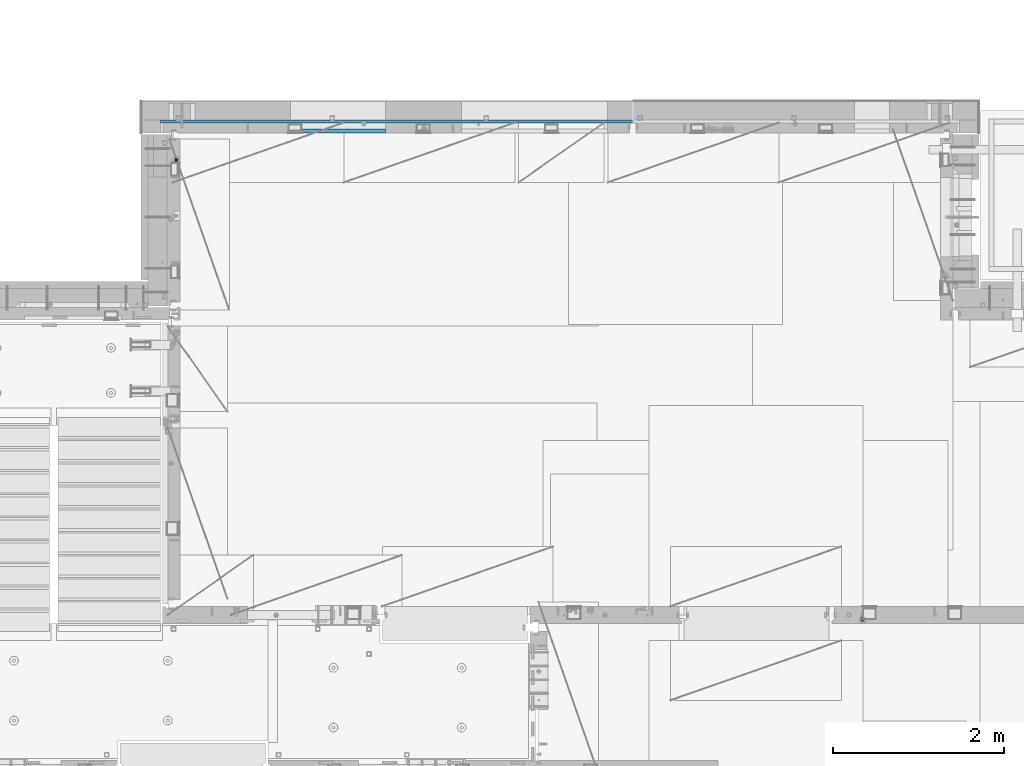
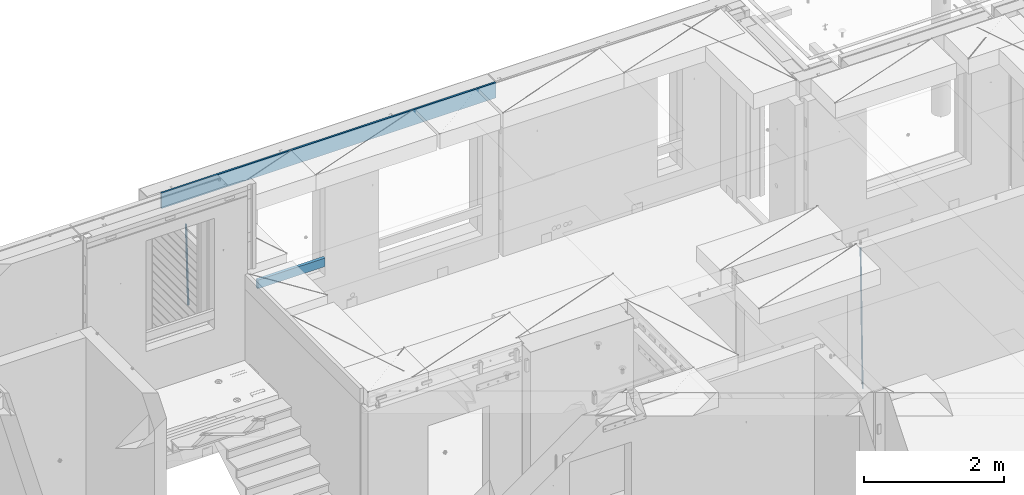
# One storey, part 108 of 325: 4 beams, 3 elements without a shape of their own.
"""IFC2X3 building model written with IfcOpenShell, lengths in millimetres."""

from ifc_helpers import new_model, si_unit, frame, origin_with_axes, place, context, subcontext, project, spatial, faceted_brep, material, type_object, element, aggregate, save


model = new_model("IFC2X3")

# Units and contexts
model_context = context("Model", 3, precision=1e-05, world=origin_with_axes())
body_context = subcontext(model_context, "Body", "Model", "MODEL_VIEW")
ifc_project = project(units=[si_unit("LENGTHUNIT", "METRE", prefix="MILLI"), si_unit("AREAUNIT", "SQUARE_METRE"), si_unit("VOLUMEUNIT", "CUBIC_METRE"), si_unit("MASSUNIT", "GRAM", prefix="KILO"), si_unit("TIMEUNIT", "SECOND"), si_unit("PLANEANGLEUNIT", "RADIAN"), si_unit("SOLIDANGLEUNIT", "STERADIAN"), si_unit("THERMODYNAMICTEMPERATUREUNIT", "DEGREE_CELSIUS"), si_unit("LUMINOUSINTENSITYUNIT", "LUMEN")], contexts=[model_context])

# Site, building, storey
site_placement = place(None, origin_with_axes())
site = spatial("IfcSite", under=ifc_project, at=site_placement, CompositionType="ELEMENT")
building_placement = place(site_placement, origin_with_axes())
building = spatial("IfcBuilding", under=site, at=building_placement, CompositionType="ELEMENT")
storey_placement = place(building_placement, origin_with_axes())
storey = spatial("IfcBuildingStorey", under=building, at=storey_placement, Name="1", CompositionType="ELEMENT", Elevation=0.0)

# Assembly, beam
assembly_1_placement = place(storey_placement, origin_with_axes())
assembly_1 = element("IfcElementAssembly", 1, at=assembly_1_placement, inside=storey, AssemblyPlace="NOTDEFINED", PredefinedType="REINFORCEMENT_UNIT")
ifc_material_1 = material()
beam_type_1 = type_object("IfcBeamType", Name="D20", PredefinedType="NOTDEFINED")
beam_1_placement = place(assembly_1_placement, frame((30400.0000000039, 16915.0002418615, 81990.0), z_axis=(-0.000205762999925498, 0.999642804629538, -0.0267249099901004), x_axis=(4.30000201928125e-08, 0.0267249099948059, 0.999642825806181)))
beam_1 = element("IfcBeam", 2, at=beam_1_placement, type_object=beam_type_1, material=ifc_material_1, Name="JM20", ObjectType="D20", context=body_context, shape_type="Brep", body=[
    faceted_brep([(0.0, -10.0, 0.0), (-4.19531716033816e-08, -7.07106781186667, -7.07106781187031), (60.4266690400545, -7.0710677960451, -7.07106780570757), (60.4266690441291, -9.99999998418934, 6.15546014159918e-09), (0.0, 0.0, -10.0), (60.426669036824, 1.58106558956206e-08, -9.99999999384454), (4.196772351861e-08, 7.07106781186303, -7.07106781186667), (60.4266690363438, 7.07106782768096, -7.07106780570757), (0.0, 10.0, 0.0), (60.4266690388904, 10.0000000158179, 6.15182216279209e-09), (4.196772351861e-08, 7.07106781185939, 7.07106781185939), (60.4266690429649, 7.07106782768096, 7.07106781802577), (0.0, 0.0, 10.0), (60.4266690461809, 1.58179318532348e-08, 10.0000000061555), (-4.19531716033816e-08, -7.07106781187031, 7.07106781185939), (60.4266690466611, -7.07106779605238, 7.07106781802213), (61.0378400410118, -7.07106779588503, -7.07106780564936), (60.991799419251, -9.99999998403655, 6.21366780251265e-09), (61.0569027789461, 1.5985278878361e-08, -9.99999999378269), (61.0378209396877, 7.07106782784831, -7.07106780564936), (60.9917724058905, 10.0000000159635, 6.21366780251265e-09), (60.9457317841297, 7.07106782781193, 7.0710678180767), (60.9266690461809, 1.59488990902901e-08, 10.0000000062028), (60.9457508854539, -7.07106779591413, 7.0710678180767), (61.6489592143771, -7.07106614513759, -7.06310863441468), (61.5568818710308, -9.9999984576425, 0.00735959856683621), (61.6870830769039, 1.71821739058942e-06, -9.99179257185824), (61.6489210170112, 7.07106947854481, -7.06310888312146), (61.556827851804, 10.0000015422847, 0.00735924683976918), (61.4647505084577, 7.07106922979438, 7.07782747982128), (61.4266266459163, 1.36643211590126e-06, 10.0065114172685), (61.464788705809, -7.07106639389531, 7.07782772852806), (176.543135720174, -7.07075579406956, -5.56673531796696), (176.451058376813, -9.99968810657447, 1.50373291501455), (176.581259582701, 0.000312069292704109, -8.49541925541052), (176.543097522794, 7.07137982961285, -5.56673556667374), (176.451004357587, 10.00031189336, 1.50373256329476), (176.35892701424, 7.07137958085514, 8.57420079627263), (176.320803151699, 0.000311717507429421, 11.5028847337162), (176.358965211621, -7.07075604281999, 8.57420104497578), (177.098753836006, -7.07075429323595, -5.55949898843028), (176.98362511232, -9.99968666800123, 1.510669025065), (177.146421932586, 0.000313595905026887, -8.48805862247536), (177.098706077581, 7.07138133041735, -5.55949936166144), (176.983557571715, 10.0003133318824, 1.51066849724157), (176.868428848029, 7.07138095712435, 8.58083651073321), (176.820760751449, 0.000313067976094317, 11.5093961447819), (176.868476606425, -7.07075466652896, 8.58083688396073), (177.654312950661, -7.07075204110879, -5.54863964998367), (177.516135294456, -9.99968450931192, 1.52107783331303), (177.711524267797, 0.000315886711177882, -8.47701274570863), (177.654255632195, 7.07138358250813, -5.54864021007961), (177.516054233929, 10.0003154905207, 1.5210770412159), (177.377876577739, 7.0713830223176, 8.59079452451624), (177.320665260588, 0.000315094497636892, 11.5191676202448), (177.377933896176, -7.07075260129932, 8.59079508461218), (299.499456785634, -7.07025810522464, -3.16697112782276), (299.361279129444, -9.99919057342777, 3.90274635547394), (299.556668102785, 0.000809822595329024, -6.09534422354773), (299.499399467197, 7.07187751838501, -3.1669716879187), (299.361198068917, 10.0008094264049, 3.90274556338045), (299.223020412712, 7.07187695819448, 10.9724630466735), (299.165809095575, 0.000809030381788034, 13.9008361423985), (299.223077731163, -7.07025866542244, 10.9724636067695), (300.03174732349, -7.07025594743027, -3.15656661289177), (299.971788958996, -9.99918809853989, 3.91467979818117), (300.056572611924, 0.000811849109595641, -6.08557274808481), (300.031722507032, 7.07187967631762, -3.15656653768019), (299.971753863239, 10.0008119014747, 3.91467990454839), (299.91179549876, 7.07187975035777, 10.9859263156177), (299.886970210311, 0.000811953817901667, 13.9149324508144), (299.911820315203, -7.0702558733974, 10.9859262404061), (300.564137759997, -7.07025623699155, -3.15794273276697), (300.582413367199, -9.99918843065097, 3.91310145956595), (300.556570941641, 0.000811577163403854, -6.0868651410201), (300.564145451674, 7.07187938674906, -3.15794274158179), (300.582424244858, 10.0008115693345, 3.91310144710224), (300.600699852032, 7.07187937566778, 10.9841456394352), (300.608266670402, 0.000811561512819026, 13.9130680476919), (300.600692160384, -7.07025624805829, 10.98414564825), (2294.16589219622, -7.0713405251372, -8.31099358700158), (2294.1841678034, -10.0002727187966, -1.23994939466866), (2294.15832537785, -0.000272710982244462, -11.2399159952547), (2294.16589988787, 7.07079509858886, -8.31099359582004), (2294.18417868105, 9.99972728118883, -1.23994940713601), (2294.20245428824, 7.07079508752213, 5.83109478519327), (2294.2100211066, -0.00027272663282929, 8.76001719345368), (2294.20244659658, -7.07134053620393, 5.83109479401173), (2294.7782683276, -7.07134085819416, -8.31257645345977), (2294.72126025338, -10.000273010919, -1.24133766827799), (2294.84007459224, -0.000273081772320438, -11.2416781768807), (2294.87047377572, 7.07079471537872, -8.31281477453012), (2294.85165844864, 9.9997269181622, -1.24167470516841), (2294.7946503744, 7.07079476544459, 5.82956408001337), (2294.73284410976, -0.000273010977252852, 8.75866580342336), (2294.7024449263, -7.07134080815013, 5.82980240107645), (2295.39054023061, -7.0793250091956, -8.30442771922026), (2295.25826128852, -10.0072756143927, -1.23419071494573), (2295.52170777075, -0.00916171800054144, -11.2326063125765), (2295.57492774284, 7.06160849139269, -8.30343918807193), (2295.51902460904, 9.99102432676591, -1.23279272078435), (2295.38674566693, 7.06307372157607, 5.83744428349019), (2295.25557812679, -0.0070895696117077, 8.76562287684646), (2295.20235815471, -7.07785977901949, 5.83645575234186), (2317.1947101649, -7.36365585014573, -8.01423575520312), (2317.06243122277, -10.2916064553428, -0.94399875092131), (2317.32587770502, -0.293492558957951, -10.9424143485521), (2317.37909767711, 6.77727765044983, -8.01324722405116), (2317.32319454331, 9.70669348581578, -0.942600756767206), (2317.1909156012, 6.77874288063322, 6.12763624751096), (2317.05974806109, -0.291420410569117, 9.0558148408636), (2317.00652808898, -7.36219061996962, 6.12664771636264), (2317.83015404257, -7.37194216843636, -8.00577862486898), (2317.72252095213, -10.300214160583, -0.935213608652703), (2317.90419832576, -0.301033978277701, -10.9347174723516), (2317.90127966482, 6.77046829039318, -8.00629749759901), (2317.82310777172, 9.70017451494641, -0.935947405505431), (2317.71547468127, 6.77190252279979, 6.13461761071085), (2317.64143039809, -0.29900566735887, 9.06355645819713), (2317.64434905903, -7.37050793602975, 6.13513648344451), (2318.46565174212, -7.3700661537805, -7.99751648408346), (2318.38266643914, -10.2982456018653, -0.926623872735945), (2318.48256818345, -0.299336209594912, -10.9272153854981), (2318.42350634121, 6.77200652527245, -7.99954269419686), (2318.32306384158, 9.70166538090416, -0.929489366557391), (2318.2400785386, 6.77348593281204, 6.14140324480104), (2318.22316209726, -0.297244011366274, 9.07110214621207), (2318.2822239395, -7.36858674623363, 6.1434294549108), (2418.48643733139, -7.07180401323421, -6.70013846199799), (2418.4034520284, -9.99998346132634, 0.370754149349523), (2418.5033537727, -0.00107406904135132, -9.62983736341266), (2418.44429193046, 7.07026866581873, -6.70216467211139), (2418.34384943081, 9.99992752145772, 0.367888655531715), (2418.26086412782, 7.0717480733656, 7.43878126688651), (2418.24394768651, 0.00101812917273492, 10.3684801682975), (2418.30300952874, -7.07032460568735, 7.44080747699627)], [[[0, 1, 2, 3]], [[1, 4, 5, 2]], [[4, 6, 7, 5]], [[6, 8, 9, 7]], [[8, 10, 11, 9]], [[10, 12, 13, 11]], [[12, 14, 15, 13]], [[14, 0, 3, 15]], [[14, 12, 10, 8, 6, 4, 1, 0]], [[3, 2, 16, 17]], [[2, 5, 18, 16]], [[5, 7, 19, 18]], [[7, 9, 20, 19]], [[9, 11, 21, 20]], [[11, 13, 22, 21]], [[13, 15, 23, 22]], [[15, 3, 17, 23]], [[17, 16, 24, 25]], [[16, 18, 26, 24]], [[18, 19, 27, 26]], [[19, 20, 28, 27]], [[20, 21, 29, 28]], [[21, 22, 30, 29]], [[22, 23, 31, 30]], [[23, 17, 25, 31]], [[25, 24, 32, 33]], [[24, 26, 34, 32]], [[26, 27, 35, 34]], [[27, 28, 36, 35]], [[28, 29, 37, 36]], [[29, 30, 38, 37]], [[30, 31, 39, 38]], [[31, 25, 33, 39]], [[33, 32, 40, 41]], [[32, 34, 42, 40]], [[34, 35, 43, 42]], [[35, 36, 44, 43]], [[36, 37, 45, 44]], [[37, 38, 46, 45]], [[38, 39, 47, 46]], [[39, 33, 41, 47]], [[41, 40, 48, 49]], [[40, 42, 50, 48]], [[42, 43, 51, 50]], [[43, 44, 52, 51]], [[44, 45, 53, 52]], [[45, 46, 54, 53]], [[46, 47, 55, 54]], [[47, 41, 49, 55]], [[49, 48, 56, 57]], [[48, 50, 58, 56]], [[50, 51, 59, 58]], [[51, 52, 60, 59]], [[52, 53, 61, 60]], [[53, 54, 62, 61]], [[54, 55, 63, 62]], [[55, 49, 57, 63]], [[57, 56, 64, 65]], [[56, 58, 66, 64]], [[58, 59, 67, 66]], [[59, 60, 68, 67]], [[60, 61, 69, 68]], [[61, 62, 70, 69]], [[62, 63, 71, 70]], [[63, 57, 65, 71]], [[65, 64, 72, 73]], [[64, 66, 74, 72]], [[66, 67, 75, 74]], [[67, 68, 76, 75]], [[68, 69, 77, 76]], [[69, 70, 78, 77]], [[70, 71, 79, 78]], [[71, 65, 73, 79]], [[73, 72, 80, 81]], [[72, 74, 82, 80]], [[74, 75, 83, 82]], [[75, 76, 84, 83]], [[76, 77, 85, 84]], [[77, 78, 86, 85]], [[78, 79, 87, 86]], [[79, 73, 81, 87]], [[81, 80, 88, 89]], [[80, 82, 90, 88]], [[82, 83, 91, 90]], [[83, 84, 92, 91]], [[84, 85, 93, 92]], [[85, 86, 94, 93]], [[86, 87, 95, 94]], [[87, 81, 89, 95]], [[89, 88, 96, 97]], [[88, 90, 98, 96]], [[90, 91, 99, 98]], [[91, 92, 100, 99]], [[92, 93, 101, 100]], [[93, 94, 102, 101]], [[94, 95, 103, 102]], [[95, 89, 97, 103]], [[97, 96, 104, 105]], [[96, 98, 106, 104]], [[98, 99, 107, 106]], [[99, 100, 108, 107]], [[100, 101, 109, 108]], [[101, 102, 110, 109]], [[102, 103, 111, 110]], [[103, 97, 105, 111]], [[105, 104, 112, 113]], [[104, 106, 114, 112]], [[106, 107, 115, 114]], [[107, 108, 116, 115]], [[108, 109, 117, 116]], [[109, 110, 118, 117]], [[110, 111, 119, 118]], [[111, 105, 113, 119]], [[113, 112, 120, 121]], [[112, 114, 122, 120]], [[114, 115, 123, 122]], [[115, 116, 124, 123]], [[116, 117, 125, 124]], [[117, 118, 126, 125]], [[118, 119, 127, 126]], [[119, 113, 121, 127]], [[121, 120, 128, 129]], [[120, 122, 130, 128]], [[122, 123, 131, 130]], [[123, 124, 132, 131]], [[124, 125, 133, 132]], [[125, 126, 134, 133]], [[126, 127, 135, 134]], [[127, 121, 129, 135]], [[130, 131, 132, 133, 134, 135, 129, 128]]]),
])
aggregate(assembly_1, [beam_1])

assembly_2_placement = place(storey_placement, origin_with_axes())
assembly_2 = element("IfcElementAssembly", 3, at=assembly_2_placement, inside=storey, Name="(PD)", AssemblyPlace="NOTDEFINED", PredefinedType="REINFORCEMENT_UNIT")
beam_type_2 = type_object("IfcBeamType", Name="D25", PredefinedType="NOTDEFINED")
beam_2_placement = place(assembly_2_placement, frame((22375.0000022791, 22305.0000022831, 82990.0), z_axis=(-0.999642804636942, -0.000205726999925762, -0.0267249099902983), x_axis=(-0.0267249099948371, 4.30000201934385e-08, 0.999642825806181)))
beam_2 = element("IfcBeam", 4, at=beam_2_placement, type_object=beam_type_2, material=ifc_material_1, Name="JM25", ObjectType="D25", context=body_context, shape_type="Brep", body=[
    faceted_brep([(-7.41420080885291e-08, -12.5, -3.63797880709171e-12), (-6.42030499875546e-08, -10.8253175473074, -6.25000000000364), (60.4103898235917, -10.8253175318459, -6.2499999938409), (60.4103898269532, -12.4999999845422, 6.16273609921336e-09), (-3.70782800018787e-08, -6.25000000000364, -10.8253175473074), (60.4103898202884, -6.24999998454587, -10.8253175411446), (-1.45519152283669e-11, -3.63797880709171e-12, -12.5), (60.4103898179019, 1.54577719513327e-08, -12.4999999938373), (3.70637280866504e-08, 6.25, -10.8253175473074), (60.410389817087, 6.25000001545777, -10.825317541141), (6.42030499875546e-08, 10.8253175473001, -6.25000000000364), (60.410389818062, 10.8253175627578, -6.24999999383726), (7.41420080885291e-08, 12.4999999999927, 0.0), (60.4103898205503, 12.5000000154541, 6.16273609921336e-09), (6.42176019027829e-08, 10.8253175473001, 6.24999999999636), (60.4103898238973, 10.8253175627651, 6.2500000061591), (3.70928319171071e-08, 6.24999999999636, 10.8253175473037), (60.4103898272151, 6.25000001546141, 10.8253175534664), (1.45519152283669e-11, -3.63797880709171e-12, 12.4999999999964), (60.4103898296162, 1.54541339725256e-08, 12.5000000061591), (-3.7049176171422e-08, -6.25000000000364, 10.8253175473001), (60.4103898304165, -6.24999998454587, 10.8253175534701), (-6.41884980723262e-08, -10.8253175473074, 6.25), (60.4103898294561, -10.8253175318459, 6.25000000616637), (61.0324985728803, -10.8253175316895, -6.24999999377542), (60.991802792938, -12.4999999843931, 6.22458173893392e-09), (61.0622854283865, -6.24999998437852, -10.8253175410755), (61.0731819955545, 1.5628756955266e-08, -12.4999999937718), (61.0622685480339, 6.25000001562512, -10.8253175410791), (61.032469335245, 10.8253175629216, -6.24999999377178), (60.9917690322181, 12.5000000156033, 6.22458173893392e-09), (60.9510732522613, 10.8253175629034, 6.25000000621731), (60.9212863967696, 6.25000001558874, 10.8253175535247), (60.9103898296162, 1.55814632307738e-08, 12.5000000062137), (60.9213032771368, -6.24999998441126, 10.8253175535174), (60.9511024898966, -10.8253175317113, 6.25000000621731), (61.6545545670233, -10.8253158516927, -6.24189838219536), (61.573166454793, -12.499998414296, 0.00757164385504439), (61.7141257553885, -6.24999822394238, -10.8168280205282), (61.7359179680789, 1.80548886419274e-06, -12.491368569139), (61.7140919992817, 6.25000177601396, -10.8168282403167), (61.6544960997562, 10.8253192428383, -6.2418987628771), (61.5730989426083, 12.5000015856094, 0.0075712042817031), (61.4917108303925, 10.8253190230062, 6.25704123032847), (61.4321396420273, 6.25000139525582, 10.8319708686649), (61.4103474293224, 1.36582457344048e-06, 12.5065114172721), (61.4321733981196, -6.24999860470052, 10.8319710884571), (61.4917692976451, -10.8253160715249, 6.25704161101385), (176.524302641745, -10.8250056210964, -4.74584321979273), (176.442914529529, -12.4996881836996, 1.50362680625403), (176.583873830095, -6.24968799334965, -9.3207728581292), (176.605666042786, 0.000312036081595579, -10.9953134067364), (176.583840074018, 6.25031200660669, -9.32077307791769), (176.524244174492, 10.8256294734347, -4.74584360047811), (176.44284701733, 12.5003118162058, 1.50362636668069), (176.361458905099, 10.8256292535989, 7.75309639272746), (176.301887716749, 6.25031162585219, 12.3280260310676), (176.280095504058, 0.000311596420942806, 14.0025665796711), (176.301921472827, -6.24968837410415, 12.3280262508561), (176.361517372367, -10.8250058409321, 7.75309677341284), (177.085397012124, -10.8250041057399, -4.73853556792164), (176.983633547483, -12.4996867233749, 1.51066909103247), (177.159881729676, -6.24968643771717, -9.31327097355097), (177.187129580227, 0.000313606451527448, -10.987740468332), (177.159839524218, 6.25031356221734, -9.31327130338468), (177.085323910098, 10.8256309887511, -4.73853613920801), (176.983549136537, 12.5003132764905, 1.51066843136869), (176.881785671867, 10.8256306588555, 7.7598730903228), (176.80730095433, 6.25031299082912, 12.3346084959521), (176.780053103794, 0.000312946667690994, 14.0090779907332), (176.807343159802, -6.2496870091054, 12.3346088257895), (176.881858773908, -10.8250044356355, 7.7598736616128), (177.646431799818, -10.8250018318176, -4.72756919822132), (177.524295146417, -12.4996845320202, 1.52123723245313), (177.735828462886, -6.24968410334986, -9.30201312475765), (177.768531371941, 0.00031596292683389, -10.9763759912421), (177.735777808921, 6.25031589654827, -9.30201361973741), (177.646344064575, 10.8256332626152, -4.72757005553649), (177.524193838486, 12.5003154677688, 1.52123624250817), (177.402057185071, 10.8256327675663, 7.77004267317898), (177.312660521988, 6.2503150390985, 12.3444865997226), (177.279957612933, 0.00031497282179771, 14.0188494661961), (177.312711175953, -6.24968496079964, 12.3444870946951), (177.402144920314, -10.8250023268702, 7.77004353049415), (299.450416306776, -10.8245081491878, -2.34670520440704), (299.32827965336, -12.4991908493976, 3.9021012262674), (299.539812969844, -6.24919042071997, -6.92114913095065), (299.572515878914, 0.000809645553090377, -8.59551199742418), (299.539762315893, 6.25080957917817, -6.9211496259195), (299.450328571547, 10.8261269452451, -2.34670606172585), (299.328178345429, 12.5008091504023, 3.9021002363188), (299.206041692043, 10.8261264501925, 10.1509066669969), (299.11664502896, 6.25080872172475, 14.7253505935405), (299.083942119891, 0.000808655455330154, 16.3997134600104), (299.116695682911, -6.24919127817338, 14.7253510885093), (299.206129427272, -10.8245086442366, 10.1509075243121), (300.022114107283, -10.8245058320463, -2.33553040816332), (299.97179243555, -12.4991882411778, 3.91467976726199), (300.058946494231, -6.24918831662217, -6.9110017919993), (300.072420388053, 0.000811671710835071, -8.58574052196127), (300.058925469799, 6.25081168339239, -6.91100170781283), (300.022077691901, 10.8261292625939, -2.33553026234586), (299.971750386685, 12.5008117588586, 3.91467993563856), (299.921428714966, 10.8261293497235, 10.1648901110639), (299.884596327989, 6.25081183430666, 14.7403614948998), (299.871122434168, 0.000811845966381952, 16.4151002248582), (299.884617352436, -6.24918816571881, 14.7403614107134), (299.921465130334, -10.8245057449167, 10.1648899652428), (300.593917726728, -10.8245062259339, -2.33749813354007), (300.615424329342, -12.4991886845492, 3.91246486206001), (300.578176108116, -6.24918867429733, -6.91278859651356), (300.572417427509, 0.00081132728519151, -8.58746114217138), (300.578184718717, 6.25081132569903, -6.91278861431056), (300.59393264071, 10.8261288686736, -2.33749816436102), (300.615441550515, 12.5008113154472, 3.91246482646966), (300.636948153115, 10.8261288568356, 10.1624278220661), (300.652689771727, 6.25081130520266, 14.7377182850432), (300.658448452334, 0.000811303612863412, 16.4123908306974), (300.65268116114, -6.24918869479734, 14.7377183028366), (300.636933239148, -10.8245062377719, 10.162427852887), (1293.8225958722, -10.8251904135213, -5.7554570479515), (1293.84410247482, -12.4998728721366, 0.494505947652215), (1293.80685425361, -6.2498728618848, -10.330747510925), (1293.801095573, 0.000127139694086509, -12.0054200565755), (1293.80686286419, 6.25012713810793, -10.3307475287183), (1293.82261078618, 10.8254446810788, -5.75545707877609), (1293.84411969599, 12.5001271278561, 0.49450591205823), (1293.86562629859, 10.8254446692445, 6.7444689076583), (1293.8813679172, 6.25012711760428, 11.3197593706318), (1293.88712659782, 0.00012711602539639, 12.994431916286), (1293.88135930662, -6.24987288238844, 11.3197593884252), (1293.86561138462, -10.8251904253593, 6.7444689384829), (1294.43576264779, -10.8251908359052, -5.75756711474241), (1294.39401066334, -12.4998732509448, 0.492613570157118), (1294.4881651176, -6.24987333120953, -10.3330920792978), (1294.53717687333, 0.000126632643514313, -12.0079531043048), (1294.56966525462, 6.25012661264918, -10.3333725306838), (1294.5769250259, 10.8254441614699, -5.75805287079493), (1294.55701093735, 12.5001266367835, 0.492052667374082), (1294.51525895292, 10.825444221744, 6.74223335227362), (1294.46285648308, 6.25012671704826, 11.3177583168253), (1294.41384472734, 0.000126753191580065, 12.9926193418323), (1294.38135634607, -6.24987322681045, 11.318038768215), (1294.37409657479, -10.8251907756348, 6.74271910832613), (1295.04882664244, -10.8331853159034, -5.74940783883358), (1294.94382667454, -12.5070429642874, 0.499931077909423), (1295.16936177819, -6.25875627512141, -10.3240260249331), (1295.27313478947, -0.00947040924438625, -11.9981582317523), (1295.33233978174, 6.24018118068125, -10.3232220864411), (1295.33111282514, 10.8156093981706, -5.74801537651729), (1295.26978268167, 12.4908319473179, 0.501538954897114), (1295.16478271378, 10.8169742989339, 6.75087787164011), (1295.04424757806, 6.24254525814467, 11.3254960577397), (1294.94047456676, -0.00674060772507801, 12.9996282645552), (1294.88126957447, -6.25639219765071, 11.3246921192476), (1294.88249653111, -10.8318204151437, 6.74948540932019), (1316.80386422646, -11.116875459662, -5.45986978806832), (1316.69886425855, -12.790733108046, 0.789469128674682), (1316.92439936219, -6.54244641887635, -10.0344879741715), (1317.02817237348, -0.293160553006601, -11.7086201809871), (1317.08737736575, 5.95649103692267, -10.0336840356795), (1317.08615040916, 10.5319192544084, -5.45847732575203), (1317.02482026568, 12.2071418035557, 0.791077005658735), (1316.91982029779, 10.5332841551717, 7.0404159223981), (1316.79928516207, 5.9588551143861, 11.6150341085013), (1316.69551215076, -0.290430751483655, 13.2891663153168), (1316.63630715849, -6.54008234141656, 11.6142301700129), (1316.6375341151, -11.1155105589023, 7.03902346008545), (1317.48953548315, -11.1258167532178, -5.45074418126023), (1317.39899812841, -12.7998629970425, 0.798787218573125), (1317.57265877169, -6.55089985429368, -10.0258602820722), (1317.62609517592, -0.300957588759047, -11.7006624193855), (1317.63552645453, 5.94934306058713, -10.0263887130131), (1317.59842550401, 10.5252390823007, -5.4516594505003), (1317.52473349411, 12.2006228327155, 0.79773035668768), (1317.43419613934, 10.5265765888907, 7.0472617565174), (1317.35107285083, 5.95165968996662, 11.6223778573367), (1317.2976364466, -0.29828257556801, 13.2971799946463), (1317.28820516799, -6.54858322491418, 11.6229062882776), (1317.32530611851, -11.1244792466277, 7.04817702575747), (1318.17526469367, -11.1237887330935, -5.44182040245869), (1318.09919107273, -12.797775016028, 0.807903115066438), (1318.22097315147, -6.5489957269856, -10.0174341323618), (1318.22406890181, -0.299208089221793, -11.6929060708244), (1318.18372244084, 5.95094862978294, -10.0192948650074), (1318.11074457024, 10.526749984605, -5.44504328594121), (1318.02468965146, 12.2021136975018, 0.804181649778911), (1317.94861603052, 10.52812741456, 7.05390516730768), (1317.90290757272, 5.95333440845207, 11.6295188972072), (1317.8998118224, -0.296453229308099, 13.3049908356734), (1317.94015828335, -6.54660994831283, 11.6313796298491), (1318.01313615397, -11.1224113031385, 7.0571280507902), (1418.17602640855, -10.8255863639497, -4.14470589025586), (1418.09995278763, -12.4995726468842, 2.10501762727654), (1418.22173486637, -6.25079335783812, -8.72031962014808), (1418.2248306167, -0.00100572007431765, -10.3957915586216), (1418.18448415573, 6.24915099893042, -8.72218035279366), (1418.11150628512, 10.8249523537488, -4.14792877373111), (1418.02545136634, 12.500316066642, 2.10129616199265), (1417.94937774542, 10.8263297837075, 8.35101967951414), (1417.90366928761, 6.2515367775959, 12.9266334094173), (1417.90057353729, 0.00174913983573788, 14.6021053478798), (1417.94091999825, -6.248407579169, 12.9284941420592), (1418.01389786886, -10.824208933991, 8.35424256299666)], [[[0, 1, 2, 3]], [[1, 4, 5, 2]], [[4, 6, 7, 5]], [[6, 8, 9, 7]], [[8, 10, 11, 9]], [[10, 12, 13, 11]], [[12, 14, 15, 13]], [[14, 16, 17, 15]], [[16, 18, 19, 17]], [[18, 20, 21, 19]], [[20, 22, 23, 21]], [[22, 0, 3, 23]], [[22, 20, 18, 16, 14, 12, 10, 8, 6, 4, 1, 0]], [[3, 2, 24, 25]], [[2, 5, 26, 24]], [[5, 7, 27, 26]], [[7, 9, 28, 27]], [[9, 11, 29, 28]], [[11, 13, 30, 29]], [[13, 15, 31, 30]], [[15, 17, 32, 31]], [[17, 19, 33, 32]], [[19, 21, 34, 33]], [[21, 23, 35, 34]], [[23, 3, 25, 35]], [[25, 24, 36, 37]], [[24, 26, 38, 36]], [[26, 27, 39, 38]], [[27, 28, 40, 39]], [[28, 29, 41, 40]], [[29, 30, 42, 41]], [[30, 31, 43, 42]], [[31, 32, 44, 43]], [[32, 33, 45, 44]], [[33, 34, 46, 45]], [[34, 35, 47, 46]], [[35, 25, 37, 47]], [[37, 36, 48, 49]], [[36, 38, 50, 48]], [[38, 39, 51, 50]], [[39, 40, 52, 51]], [[40, 41, 53, 52]], [[41, 42, 54, 53]], [[42, 43, 55, 54]], [[43, 44, 56, 55]], [[44, 45, 57, 56]], [[45, 46, 58, 57]], [[46, 47, 59, 58]], [[47, 37, 49, 59]], [[49, 48, 60, 61]], [[48, 50, 62, 60]], [[50, 51, 63, 62]], [[51, 52, 64, 63]], [[52, 53, 65, 64]], [[53, 54, 66, 65]], [[54, 55, 67, 66]], [[55, 56, 68, 67]], [[56, 57, 69, 68]], [[57, 58, 70, 69]], [[58, 59, 71, 70]], [[59, 49, 61, 71]], [[61, 60, 72, 73]], [[60, 62, 74, 72]], [[62, 63, 75, 74]], [[63, 64, 76, 75]], [[64, 65, 77, 76]], [[65, 66, 78, 77]], [[66, 67, 79, 78]], [[67, 68, 80, 79]], [[68, 69, 81, 80]], [[69, 70, 82, 81]], [[70, 71, 83, 82]], [[71, 61, 73, 83]], [[73, 72, 84, 85]], [[72, 74, 86, 84]], [[74, 75, 87, 86]], [[75, 76, 88, 87]], [[76, 77, 89, 88]], [[77, 78, 90, 89]], [[78, 79, 91, 90]], [[79, 80, 92, 91]], [[80, 81, 93, 92]], [[81, 82, 94, 93]], [[82, 83, 95, 94]], [[83, 73, 85, 95]], [[85, 84, 96, 97]], [[84, 86, 98, 96]], [[86, 87, 99, 98]], [[87, 88, 100, 99]], [[88, 89, 101, 100]], [[89, 90, 102, 101]], [[90, 91, 103, 102]], [[91, 92, 104, 103]], [[92, 93, 105, 104]], [[93, 94, 106, 105]], [[94, 95, 107, 106]], [[95, 85, 97, 107]], [[97, 96, 108, 109]], [[96, 98, 110, 108]], [[98, 99, 111, 110]], [[99, 100, 112, 111]], [[100, 101, 113, 112]], [[101, 102, 114, 113]], [[102, 103, 115, 114]], [[103, 104, 116, 115]], [[104, 105, 117, 116]], [[105, 106, 118, 117]], [[106, 107, 119, 118]], [[107, 97, 109, 119]], [[109, 108, 120, 121]], [[108, 110, 122, 120]], [[110, 111, 123, 122]], [[111, 112, 124, 123]], [[112, 113, 125, 124]], [[113, 114, 126, 125]], [[114, 115, 127, 126]], [[115, 116, 128, 127]], [[116, 117, 129, 128]], [[117, 118, 130, 129]], [[118, 119, 131, 130]], [[119, 109, 121, 131]], [[121, 120, 132, 133]], [[120, 122, 134, 132]], [[122, 123, 135, 134]], [[123, 124, 136, 135]], [[124, 125, 137, 136]], [[125, 126, 138, 137]], [[126, 127, 139, 138]], [[127, 128, 140, 139]], [[128, 129, 141, 140]], [[129, 130, 142, 141]], [[130, 131, 143, 142]], [[131, 121, 133, 143]], [[133, 132, 144, 145]], [[132, 134, 146, 144]], [[134, 135, 147, 146]], [[135, 136, 148, 147]], [[136, 137, 149, 148]], [[137, 138, 150, 149]], [[138, 139, 151, 150]], [[139, 140, 152, 151]], [[140, 141, 153, 152]], [[141, 142, 154, 153]], [[142, 143, 155, 154]], [[143, 133, 145, 155]], [[145, 144, 156, 157]], [[144, 146, 158, 156]], [[146, 147, 159, 158]], [[147, 148, 160, 159]], [[148, 149, 161, 160]], [[149, 150, 162, 161]], [[150, 151, 163, 162]], [[151, 152, 164, 163]], [[152, 153, 165, 164]], [[153, 154, 166, 165]], [[154, 155, 167, 166]], [[155, 145, 157, 167]], [[157, 156, 168, 169]], [[156, 158, 170, 168]], [[158, 159, 171, 170]], [[159, 160, 172, 171]], [[160, 161, 173, 172]], [[161, 162, 174, 173]], [[162, 163, 175, 174]], [[163, 164, 176, 175]], [[164, 165, 177, 176]], [[165, 166, 178, 177]], [[166, 167, 179, 178]], [[167, 157, 169, 179]], [[169, 168, 180, 181]], [[168, 170, 182, 180]], [[170, 171, 183, 182]], [[171, 172, 184, 183]], [[172, 173, 185, 184]], [[173, 174, 186, 185]], [[174, 175, 187, 186]], [[175, 176, 188, 187]], [[176, 177, 189, 188]], [[177, 178, 190, 189]], [[178, 179, 191, 190]], [[179, 169, 181, 191]], [[181, 180, 192, 193]], [[180, 182, 194, 192]], [[182, 183, 195, 194]], [[183, 184, 196, 195]], [[184, 185, 197, 196]], [[185, 186, 198, 197]], [[186, 187, 199, 198]], [[187, 188, 200, 199]], [[188, 189, 201, 200]], [[189, 190, 202, 201]], [[190, 191, 203, 202]], [[191, 181, 193, 203]], [[194, 195, 196, 197, 198, 199, 200, 201, 202, 203, 193, 192]]]),
])
aggregate(assembly_2, [beam_2])

# Assembly, beams
assembly_3_placement = place(storey_placement, origin_with_axes())
assembly_3 = element("IfcElementAssembly", 5, at=assembly_3_placement, inside=storey, AssemblyPlace="NOTDEFINED", PredefinedType="REINFORCEMENT_UNIT")
ifc_material_2 = material(Name="TIMBER/T24")
beam_type_3 = type_object("IfcBeamType", PredefinedType="NOTDEFINED")
beam_3_placement = place(assembly_3_placement, frame((24815.0002989914, 22644.9998418812, 82685.0), z_axis=(0.0, 0.0, 1.0), x_axis=(-1.0, 3.00000001838171e-08, 0.0)))
beam_3 = element("IfcBeam", 6, at=beam_3_placement, type_object=beam_type_3, material=ifc_material_2, context=body_context, shape_type="Brep", body=[
    faceted_brep([(-3.63797880709171e-12, 24.9999999999964, -75.0), (-3.63797880709171e-12, 24.9999999999964, 75.0), (1110.0, 24.9999999999964, 75.0), (1110.0, 24.9999999999964, -75.0), (0.0, -25.0000000000073, 75.0), (1110.0, -25.0000000000073, 75.0), (0.0, -25.0000000000073, -75.0), (1110.0, -25.0000000000073, -75.0)], [[[0, 1, 2, 3]], [[1, 4, 5, 2]], [[4, 6, 7, 5]], [[6, 0, 3, 7]], [[5, 7, 3, 2]], [[6, 4, 1, 0]]]),
])
ifc_material_3 = material(Name="CONCRETE/C25/30")
beam_type_4 = type_object("IfcBeamType", Name="270X30", PredefinedType="NOTDEFINED")
beam_4_placement = place(assembly_3_placement, frame((27705.0, 22755.0, 84605.0), z_axis=(0.0, 0.0, 1.0), x_axis=(-1.0, 3.00000001838171e-08, 0.0)))
beam_4 = element("IfcBeam", 7, at=beam_4_placement, type_object=beam_type_4, material=ifc_material_3, ObjectType="270X30", context=body_context, shape_type="Brep", body=[
    faceted_brep([(0.0, 15.0, -135.0), (0.0, 15.0, 135.0), (5520.00000000003, 15.0, 135.0), (5520.00000000003, 15.0, -135.0), (0.0, -15.0, 135.0), (5520.00000000003, -15.0, 135.0), (0.0, -15.0, -135.0), (5520.00000000003, -15.0, -135.0)], [[[0, 1, 2, 3]], [[1, 4, 5, 2]], [[4, 6, 7, 5]], [[6, 0, 3, 7]], [[5, 7, 3, 2]], [[6, 4, 1, 0]]]),
])
aggregate(assembly_3, [beam_4, beam_3])

save(model, "model.ifc")
